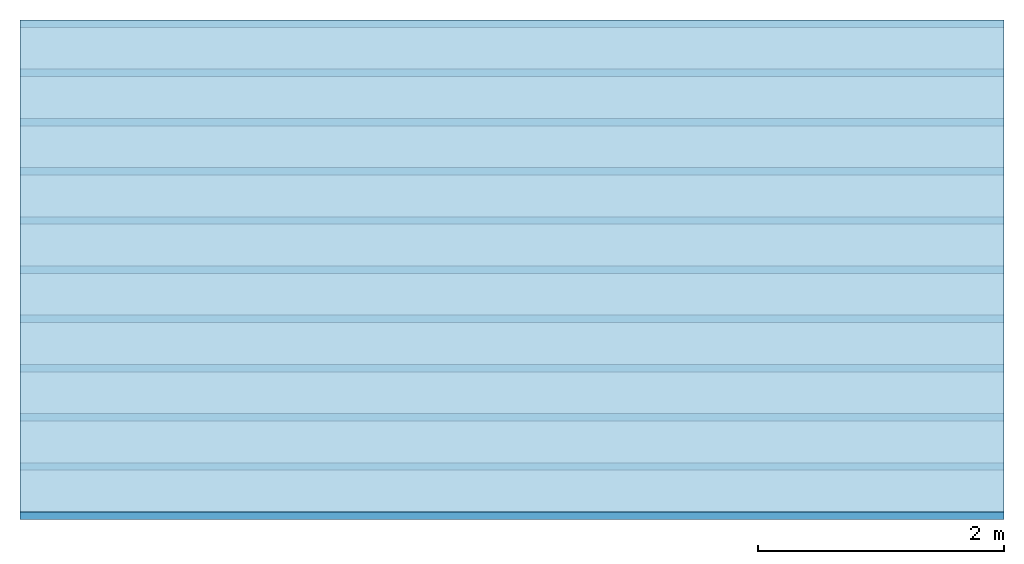
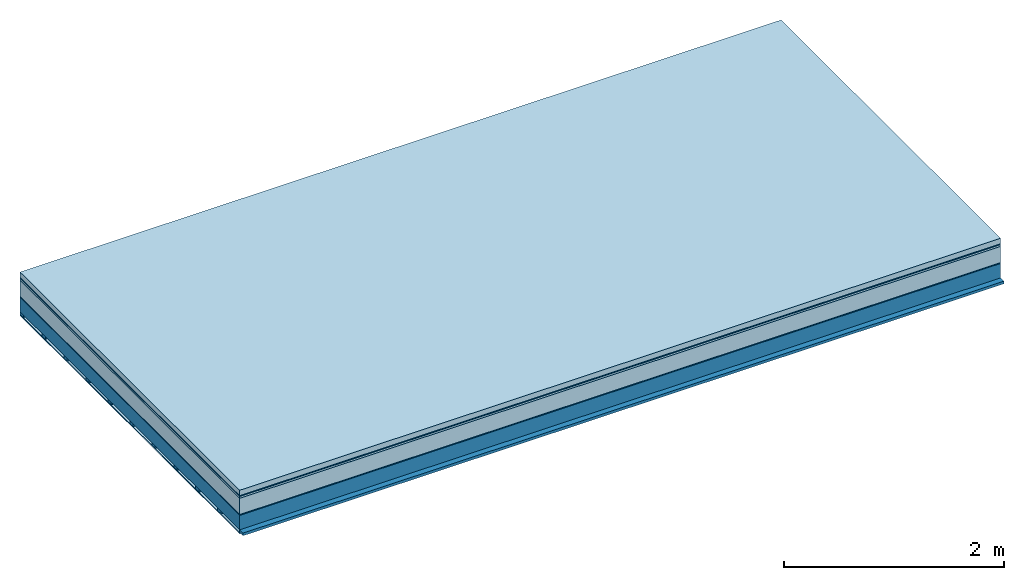
# One storey: 7 plates, 2 members, 1 element without a shape of its own.
"""IFC4 building model written with IfcOpenShell, lengths in metres."""

from ifc_helpers import new_model, si_unit, derived_unit, direction, frame, frame_2d, origin, origin_with_axes, place, context, project, spatial, rectangle, extrude, material, layer, layer_set, type_object, element, aggregate, save


model = new_model("IFC4")

# Units and contexts
plan_context = context("Plan", 3, precision=1e-05, world=origin(), true_north=direction((0.0, 1.0)))
model_context = context("Model", 3, precision=1e-05, world=origin(), true_north=direction((0.0, 1.0)))
ifc_project = project(units=[si_unit("LENGTHUNIT", "METRE"), derived_unit("SOUNDPRESSUREUNIT", [(si_unit("PRESSUREUNIT", "PASCAL", prefix="MICRO"), 0)]), si_unit("ENERGYUNIT", "JOULE", prefix="MEGA"), si_unit("MASSUNIT", "GRAM", prefix="KILO"), derived_unit("THERMALTRANSMITTANCEUNIT", [(si_unit("POWERUNIT", "WATT"), 1), (si_unit("AREAUNIT", "SQUARE_METRE"), -1), (si_unit("THERMODYNAMICTEMPERATUREUNIT", "KELVIN"), -1)]), derived_unit("AREADENSITYUNIT", [(si_unit("MASSUNIT", "GRAM", prefix="KILO"), 1), (si_unit("AREAUNIT", "SQUARE_METRE"), -1)]), derived_unit("USERDEFINED", [(si_unit("ENERGYUNIT", "JOULE", prefix="MEGA"), 1), (si_unit("AREAUNIT", "SQUARE_METRE"), -1)])], contexts=[plan_context, model_context])

# Site, building, storey
site = spatial("IfcSite", under=ifc_project)
building_placement = place(None, origin())
building = spatial("IfcBuilding", under=site, at=building_placement)
storey_placement = place(building_placement, origin())
storey = spatial("IfcBuildingStorey", under=building, at=storey_placement)

# Slab, members, plates
ifc_material_1 = material(Name="clay", Category="02.004")
ifc_layer_1 = layer(ifc_material_1, 0.06, Name="Use and protection layer 2")
ifc_material_2 = material(Name="Protective layer", Category="09.007")
ifc_layer_2 = layer(ifc_material_2, 0.01, Name="Use and protection layer 1")
ifc_material_3 = material(Name="Bituminous", Category="09.003")
ifc_layer_3 = layer(ifc_material_3, 0.02, Name="Seal")
ifc_material_4 = material(Name="Mineral wool", Category="10.008")
ifc_layer_4 = layer(ifc_material_4, 0.18, Name="Exterior insulation layer 1")
ifc_material_5 = material(Name="Vapor-permeable barrier", Category="09.006")
ifc_layer_5 = layer(ifc_material_5, 0.01, Name="layer / temporary roof")
ifc_material_6 = material(Name="no composite action")
ifc_layer_6 = layer(ifc_material_6, 0.0, Name="Bond")
ifc_layer_7 = layer(None, 0.16, Name="Support")
ifc_material_7 = material(Name="of the art")
ifc_layer_8 = layer(ifc_material_7, 0.0, Name="Bond")
ifc_layer_9 = layer(None, 0.03, Name="Battens / profiles")
ifc_material_8 = material(Name="Plasterboard type A", Category="03.008")
ifc_layer_10 = layer(ifc_material_8, 0.0125, Name="Covering below 1st layer")
ifc_material_9 = material(Category="04.001")
ifc_layer_11 = layer(ifc_material_9, 0.003, Name="Surface below")
ifc_layer_set = layer_set([ifc_layer_1, ifc_layer_2, ifc_layer_3, ifc_layer_4, ifc_layer_5, ifc_layer_6, ifc_layer_7, ifc_layer_8, ifc_layer_9, ifc_layer_10, ifc_layer_11])
slab_type = type_object("IfcSlabType", Name="F0075", PredefinedType="NOTDEFINED", material=ifc_layer_set)
slab_placement = place(None, frame((0.0, 0.0, 0.0), z_axis=(0.0, 0.0, -1.0), x_axis=(1.0, 0.0, 0.0)))
slab = element("IfcSlab", 1, at=slab_placement, inside=storey, type_object=slab_type, material=ifc_layer_set, Name="Slab #1")
ifc_material_10 = material(Name="Solid timber panel")
member_1_placement = place(slab_placement, origin())
member_1 = element("IfcMember", 2, at=member_1_placement, material=ifc_material_10, Name="Support", context=plan_context, shape_type="SweptSolid", body=[
    extrude(rectangle(XDim=1.0, YDim=0.16, at=frame_2d((0.5, 0.08), x_axis=(1.0, 0.0))), frame((0.0, 4.0, 0.28), z_axis=(0.0, -1.0, 0.0), x_axis=(1.0, 0.0, 0.0)), (0.0, 0.0, 1.0), 4.0),
    extrude(rectangle(XDim=1.0, YDim=0.16, at=frame_2d((0.5, 0.08), x_axis=(1.0, 0.0))), frame((1.0, 4.0, 0.28), z_axis=(0.0, -1.0, 0.0), x_axis=(1.0, 0.0, 0.0)), (0.0, 0.0, 1.0), 4.0),
    extrude(rectangle(XDim=1.0, YDim=0.16, at=frame_2d((0.5, 0.08), x_axis=(1.0, 0.0))), frame((2.0, 4.0, 0.28), z_axis=(0.0, -1.0, 0.0), x_axis=(1.0, 0.0, 0.0)), (0.0, 0.0, 1.0), 4.0),
    extrude(rectangle(XDim=1.0, YDim=0.16, at=frame_2d((0.5, 0.08), x_axis=(1.0, 0.0))), frame((3.0, 4.0, 0.28), z_axis=(0.0, -1.0, 0.0), x_axis=(1.0, 0.0, 0.0)), (0.0, 0.0, 1.0), 4.0),
    extrude(rectangle(XDim=1.0, YDim=0.16, at=frame_2d((0.5, 0.08), x_axis=(1.0, 0.0))), frame((4.0, 4.0, 0.28), z_axis=(0.0, -1.0, 0.0), x_axis=(1.0, 0.0, 0.0)), (0.0, 0.0, 1.0), 4.0),
    extrude(rectangle(XDim=1.0, YDim=0.16, at=frame_2d((0.5, 0.08), x_axis=(1.0, 0.0))), frame((5.0, 4.0, 0.28), z_axis=(0.0, -1.0, 0.0), x_axis=(1.0, 0.0, 0.0)), (0.0, 0.0, 1.0), 4.0),
    extrude(rectangle(XDim=1.0, YDim=0.16, at=frame_2d((0.5, 0.08), x_axis=(1.0, 0.0))), frame((6.0, 4.0, 0.28), z_axis=(0.0, -1.0, 0.0), x_axis=(1.0, 0.0, 0.0)), (0.0, 0.0, 1.0), 4.0),
    extrude(rectangle(XDim=1.0, YDim=0.16, at=frame_2d((0.5, 0.08), x_axis=(1.0, 0.0))), frame((7.0, 4.0, 0.28), z_axis=(0.0, -1.0, 0.0), x_axis=(1.0, 0.0, 0.0)), (0.0, 0.0, 1.0), 4.0),
])
ifc_material_11 = material()
member_2_placement = place(slab_placement, origin())
member_2 = element("IfcMember", 3, at=member_2_placement, material=ifc_material_11, Name="Battens / profiles", context=plan_context, shape_type="SweptSolid", body=[
    extrude(rectangle(XDim=0.06, YDim=0.03, at=frame_2d((0.03, 0.015), x_axis=(1.0, 0.0))), frame((0.0, 0.0, 0.44), z_axis=(1.0, 0.0, 0.0), x_axis=(0.0, 1.0, 0.0)), (0.0, 0.0, 1.0), 8.0),
    extrude(rectangle(XDim=0.06, YDim=0.03, at=frame_2d((0.03, 0.015), x_axis=(1.0, 0.0))), frame((0.0, 0.4, 0.44), z_axis=(1.0, 0.0, 0.0), x_axis=(0.0, 1.0, 0.0)), (0.0, 0.0, 1.0), 8.0),
    extrude(rectangle(XDim=0.06, YDim=0.03, at=frame_2d((0.03, 0.015), x_axis=(1.0, 0.0))), frame((0.0, 0.8, 0.44), z_axis=(1.0, 0.0, 0.0), x_axis=(0.0, 1.0, 0.0)), (0.0, 0.0, 1.0), 8.0),
    extrude(rectangle(XDim=0.06, YDim=0.03, at=frame_2d((0.03, 0.015), x_axis=(1.0, 0.0))), frame((0.0, 1.2, 0.44), z_axis=(1.0, 0.0, 0.0), x_axis=(0.0, 1.0, 0.0)), (0.0, 0.0, 1.0), 8.0),
    extrude(rectangle(XDim=0.06, YDim=0.03, at=frame_2d((0.03, 0.015), x_axis=(1.0, 0.0))), frame((0.0, 1.6, 0.44), z_axis=(1.0, 0.0, 0.0), x_axis=(0.0, 1.0, 0.0)), (0.0, 0.0, 1.0), 8.0),
    extrude(rectangle(XDim=0.06, YDim=0.03, at=frame_2d((0.03, 0.015), x_axis=(1.0, 0.0))), frame((0.0, 2.0, 0.44), z_axis=(1.0, 0.0, 0.0), x_axis=(0.0, 1.0, 0.0)), (0.0, 0.0, 1.0), 8.0),
    extrude(rectangle(XDim=0.06, YDim=0.03, at=frame_2d((0.03, 0.015), x_axis=(1.0, 0.0))), frame((0.0, 2.4, 0.44), z_axis=(1.0, 0.0, 0.0), x_axis=(0.0, 1.0, 0.0)), (0.0, 0.0, 1.0), 8.0),
    extrude(rectangle(XDim=0.06, YDim=0.03, at=frame_2d((0.03, 0.015), x_axis=(1.0, 0.0))), frame((0.0, 2.8, 0.44), z_axis=(1.0, 0.0, 0.0), x_axis=(0.0, 1.0, 0.0)), (0.0, 0.0, 1.0), 8.0),
    extrude(rectangle(XDim=0.06, YDim=0.03, at=frame_2d((0.03, 0.015), x_axis=(1.0, 0.0))), frame((0.0, 3.2, 0.44), z_axis=(1.0, 0.0, 0.0), x_axis=(0.0, 1.0, 0.0)), (0.0, 0.0, 1.0), 8.0),
    extrude(rectangle(XDim=0.06, YDim=0.03, at=frame_2d((0.03, 0.015), x_axis=(1.0, 0.0))), frame((0.0, 3.6, 0.44), z_axis=(1.0, 0.0, 0.0), x_axis=(0.0, 1.0, 0.0)), (0.0, 0.0, 1.0), 8.0),
    extrude(rectangle(XDim=0.06, YDim=0.03, at=frame_2d((0.03, 0.015), x_axis=(1.0, 0.0))), frame((0.0, 4.0, 0.44), z_axis=(1.0, 0.0, 0.0), x_axis=(0.0, 1.0, 0.0)), (0.0, 0.0, 1.0), 8.0),
])
plate_1_placement = place(slab_placement, origin())
plate_1 = element("IfcPlate", 4, at=plate_1_placement, material=ifc_material_1, Name="Use and protection layer 2", context=plan_context, shape_type="SweptSolid", body=[
    extrude(rectangle(XDim=8.0, YDim=4.0, at=frame_2d((4.0, 2.0), x_axis=(1.0, 0.0))), origin_with_axes(), (0.0, 0.0, 1.0), 0.06),
])
plate_2_placement = place(slab_placement, origin())
plate_2 = element("IfcPlate", 5, at=plate_2_placement, material=ifc_material_2, Name="Use and protection layer 1", context=plan_context, shape_type="SweptSolid", body=[
    extrude(rectangle(XDim=8.0, YDim=4.0, at=frame_2d((4.0, 2.0), x_axis=(1.0, 0.0))), frame((0.0, 0.0, 0.06), z_axis=(0.0, 0.0, 1.0), x_axis=(1.0, 0.0, 0.0)), (0.0, 0.0, 1.0), 0.01),
])
plate_3_placement = place(slab_placement, origin())
plate_3 = element("IfcPlate", 6, at=plate_3_placement, material=ifc_material_3, Name="Seal", context=plan_context, shape_type="SweptSolid", body=[
    extrude(rectangle(XDim=8.0, YDim=4.0, at=frame_2d((4.0, 2.0), x_axis=(1.0, 0.0))), frame((0.0, 0.0, 0.07), z_axis=(0.0, 0.0, 1.0), x_axis=(1.0, 0.0, 0.0)), (0.0, 0.0, 1.0), 0.02),
])
plate_4_placement = place(slab_placement, origin())
plate_4 = element("IfcPlate", 7, at=plate_4_placement, material=ifc_material_4, Name="Exterior insulation layer 1", context=plan_context, shape_type="SweptSolid", body=[
    extrude(rectangle(XDim=8.0, YDim=4.0, at=frame_2d((4.0, 2.0), x_axis=(1.0, 0.0))), frame((0.0, 0.0, 0.09), z_axis=(0.0, 0.0, 1.0), x_axis=(1.0, 0.0, 0.0)), (0.0, 0.0, 1.0), 0.18),
])
plate_5_placement = place(slab_placement, origin())
plate_5 = element("IfcPlate", 8, at=plate_5_placement, material=ifc_material_5, Name="layer / temporary roof", context=plan_context, shape_type="SweptSolid", body=[
    extrude(rectangle(XDim=8.0, YDim=4.0, at=frame_2d((4.0, 2.0), x_axis=(1.0, 0.0))), frame((0.0, 0.0, 0.27), z_axis=(0.0, 0.0, 1.0), x_axis=(1.0, 0.0, 0.0)), (0.0, 0.0, 1.0), 0.01),
])
plate_6_placement = place(slab_placement, origin())
plate_6 = element("IfcPlate", 9, at=plate_6_placement, material=ifc_material_8, Name="Covering below 1st layer", context=plan_context, shape_type="SweptSolid", body=[
    extrude(rectangle(XDim=8.0, YDim=4.0, at=frame_2d((4.0, 2.0), x_axis=(1.0, 0.0))), frame((0.0, 0.0, 0.47), z_axis=(0.0, 0.0, 1.0), x_axis=(1.0, 0.0, 0.0)), (0.0, 0.0, 1.0), 0.0125),
])
plate_7_placement = place(slab_placement, origin())
plate_7 = element("IfcPlate", 10, at=plate_7_placement, material=ifc_material_9, Name="Surface below", context=plan_context, shape_type="SweptSolid", body=[
    extrude(rectangle(XDim=8.0, YDim=4.0, at=frame_2d((4.0, 2.0), x_axis=(1.0, 0.0))), frame((0.0, 0.0, 0.4825), z_axis=(0.0, 0.0, 1.0), x_axis=(1.0, 0.0, 0.0)), (0.0, 0.0, 1.0), 0.003),
])
aggregate(slab, [plate_1, plate_2, plate_3, plate_4, plate_5, member_1, member_2, plate_6, plate_7])

save(model, "model.ifc")
